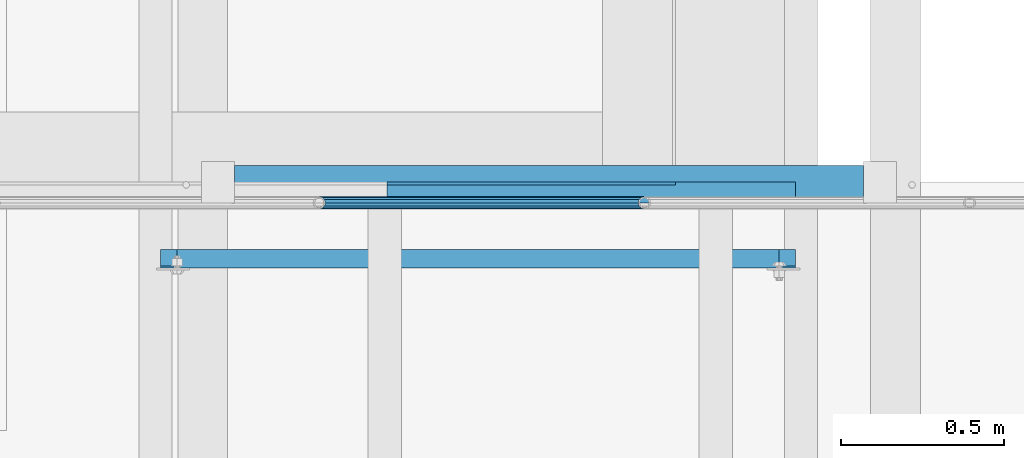
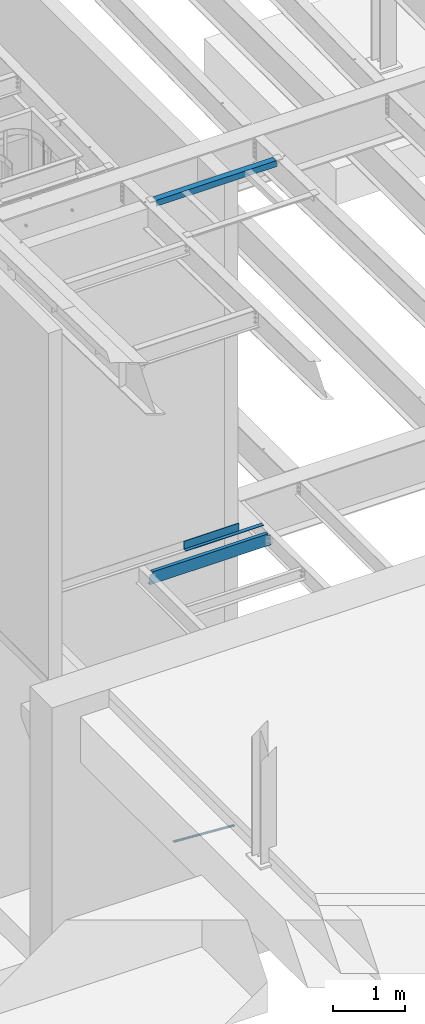
# One storey, part 1087 of 1763: 4 beams, 4 elements without a shape of their own.
"""IFC2X3 building model written with IfcOpenShell, lengths in millimetres."""

from ifc_helpers import new_model, si_unit, frame, origin_with_axes, place, context, subcontext, project, spatial, faceted_brep, material, type_object, element, aggregate, save


model = new_model("IFC2X3")

# Units and contexts
model_context = context("Model", 3, precision=1e-05, world=origin_with_axes())
body_context = subcontext(model_context, "Body", "Model", "MODEL_VIEW")
ifc_project = project(units=[si_unit("LENGTHUNIT", "METRE", prefix="MILLI"), si_unit("AREAUNIT", "SQUARE_METRE"), si_unit("VOLUMEUNIT", "CUBIC_METRE"), si_unit("MASSUNIT", "GRAM", prefix="KILO"), si_unit("TIMEUNIT", "SECOND"), si_unit("PLANEANGLEUNIT", "RADIAN"), si_unit("SOLIDANGLEUNIT", "STERADIAN"), si_unit("THERMODYNAMICTEMPERATUREUNIT", "DEGREE_CELSIUS"), si_unit("LUMINOUSINTENSITYUNIT", "LUMEN")], contexts=[model_context])

# Site, building, storey
site_placement = place(None, origin_with_axes())
site = spatial("IfcSite", under=ifc_project, at=site_placement, CompositionType="ELEMENT")
building_placement = place(site_placement, origin_with_axes())
building = spatial("IfcBuilding", under=site, at=building_placement, Name="Undefined", CompositionType="ELEMENT")
storey_placement = place(building_placement, origin_with_axes())
storey = spatial("IfcBuildingStorey", under=building, at=storey_placement, Name="Undefined", CompositionType="ELEMENT", Elevation=0.0)

# Assembly, beam
assembly_1_placement = place(storey_placement, origin_with_axes())
assembly_1 = element("IfcElementAssembly", 1, at=assembly_1_placement, inside=storey, Name="GUARDRAIL", AssemblyPlace="NOTDEFINED", PredefinedType="RIGID_FRAME")
ifc_material_1 = material()
beam_type_1 = type_object("IfcBeamType", PredefinedType="NOTDEFINED")
beam_1_placement = place(assembly_1_placement, frame((-83893.4544648736, 29197.2999999971, 277.811841144737), z_axis=(0.0, -1.0, 0.0), x_axis=(-0.997891522550524, 0.0, 0.0649038459707657)))
beam_1 = element("IfcBeam", 2, at=beam_1_placement, type_object=beam_type_1, material=ifc_material_1, Name="GUARDRAIL", context=body_context, shape_type="Brep", body=[
    faceted_brep([(1000.15019855548, 2.81943357549608e-11, -19.0499999999993), (989.985557506108, 9.5250000000251, -16.4977839420935), (991.224588240293, -9.52499999997053, -16.4977839420935), (982.257505670044, 13.3082123799786, 7.68349999999919), (980.060462398702, 15.3670000000229, 0.0), (979.820916456767, 19.050000000022, 0.0), (982.544523817283, 16.4977839421163, 9.52500000000146), (982.87174965936, 11.46671237998, 9.52500000000146), (982.87174965936, 11.46671237998, -9.52500000000146), (982.544523817283, 16.4977839421163, -9.52500000000146), (982.257505670044, 13.3082123799786, -7.68349999999919), (986.909019565966, 7.68350000002556, -13.3082123799541), (989.47189966141, 2.81943357549608e-11, -15.3669999999984), (987.908504358144, -7.68349999997099, -13.3082123799541), (984.363362158969, -11.4667123799254, -9.52500000000146), (984.690588001031, -16.4977839420635, -9.52500000000146), (983.988664111486, -13.3082123799259, -7.68349999999919), (982.059431983173, -15.3669999999702, 0.0), (982.298977925122, -19.0499999999693, 0.0), (983.988664111486, -13.3082123799259, 7.68349999999919), (984.363362158969, -11.4667123799254, 9.52500000000146), (984.690588001031, -16.4977839420635, 9.52500000000146), (1000.15019855546, 2.72848410531878e-11, 19.0499999999993), (991.224588240293, -9.52499999997053, 16.4977839420935), (989.985557506108, 9.5250000000251, 16.4977839420935), (987.908504358144, -7.68349999997099, 13.3082123799541), (989.47189966141, 2.72848410531878e-11, 15.3669999999984), (986.909019565966, 7.68350000002465, 13.3082123799541), (8.92561031517107, 9.52499999999873, -16.4977839420935), (15.4596105544624, 16.4977839420917, -9.52500000000146), (17.8512206303712, 19.0499999999975, 0.0), (18.0907665723062, 15.3669999999984, 0.0), (15.7868363965099, 11.4667123799545, -9.52500000000146), (16.1615344449092, 13.3082123799541, -7.68349999999919), (16.1615344449092, 13.3082123799541, 7.68349999999919), (15.7868363965099, 11.4667123799545, 9.52500000000146), (15.4596105544624, 16.4977839420917, 9.52500000000146), (8.92561031517107, 9.52499999999873, 16.4977839420935), (1.45519152283669e-11, 1.81898940354586e-12, 19.0499999999993), (10.1646410493704, -9.524999999996, 16.4977839420935), (10.1646410493704, -9.52499999999509, -16.4977839420935), (1.45519152283669e-11, 1.81898940354586e-12, -19.0499999999993), (17.6056747381954, -16.4977839420881, -9.52500000000146), (20.3292820987263, -19.0499999999938, 0.0), (17.6056747381954, -16.4977839420881, 9.52500000000146), (17.2784488961188, -11.4667123799518, -9.52500000000146), (13.2411789904436, -7.68349999999555, -13.3082123799541), (10.6782988949999, 1.81898940354586e-12, -15.3669999999984), (12.2416941982665, 7.68350000000009, -13.3082123799541), (20.0897361567768, -15.3669999999947, 0.0), (17.8926928863511, -13.3082123799504, -7.68349999999919), (17.2784488961188, -11.4667123799518, 9.52500000000146), (17.8926928863511, -13.3082123799504, 7.68349999999919), (12.2416941982665, 7.68350000000009, 13.3082123799541), (10.6782988949999, 1.81898940354586e-12, 15.3669999999984), (13.2411789904436, -7.68349999999646, 13.3082123799541)], [[[0, 1, 2]], [[3, 4, 5, 6, 7]], [[8, 9, 5, 4, 10]], [[2, 1, 9, 8, 11, 12, 13, 14, 15]], [[15, 14, 16, 17, 18]], [[18, 17, 19, 20, 21]], [[22, 23, 24]], [[21, 20, 25, 26, 27, 7, 6, 24, 23]], [[9, 1, 28, 29]], [[5, 9, 29, 30]], [[31, 30, 29, 32, 33]], [[34, 35, 36, 30, 31]], [[6, 5, 30, 36]], [[24, 6, 36, 37]], [[22, 24, 37, 38]], [[38, 37, 39]], [[0, 2, 40, 41]], [[2, 15, 42, 40]], [[15, 18, 43, 42]], [[18, 21, 44, 43]], [[21, 23, 39, 44]], [[23, 22, 38, 39]], [[1, 0, 41, 28]], [[40, 28, 41]], [[42, 45, 46, 47, 48, 32, 29, 28, 40]], [[43, 49, 50, 45, 42]], [[44, 51, 52, 49, 43]], [[39, 37, 36, 35, 53, 54, 55, 51, 44]], [[26, 25, 55, 54]], [[55, 25, 20, 19, 52, 51]], [[19, 17, 49, 52]], [[17, 16, 50, 49]], [[16, 14, 13, 46, 45, 50]], [[13, 12, 47, 46]], [[12, 11, 48, 47]], [[48, 11, 8, 10, 33, 32]], [[10, 4, 31, 33]], [[4, 3, 34, 31]], [[3, 7, 27, 53, 35, 34]], [[27, 26, 54, 53]]]),
])
aggregate(assembly_1, [beam_1])

assembly_2_placement = place(storey_placement, origin_with_axes())
assembly_2 = element("IfcElementAssembly", 3, at=assembly_2_placement, inside=storey, Name="ANGLE", AssemblyPlace="NOTDEFINED", PredefinedType="RIGID_FRAME")
ifc_material_2 = material(Name="STEEL/A36")
beam_type_2 = type_object("IfcBeamType", Name="L4X4X3/8", PredefinedType="NOTDEFINED")
beam_2_placement = place(assembly_2_placement, frame((-85249.0944165555, 29259.7228841285, 11255.437584779), z_axis=(0.0, -0.0209829029927569, -0.999779834654609), x_axis=(1.0, 0.0, 0.0)))
beam_2 = element("IfcBeam", 4, at=beam_2_placement, type_object=beam_type_2, material=ifc_material_2, Name="ANGLE", ObjectType="L4X4X3/8", context=body_context, shape_type="Brep", body=[
    faceted_brep([(98.4250000000029, 50.7999999999229, -50.8000000000175), (98.4250000000029, 50.8000000000102, 50.8000000001048), (2027.926333111, 50.8000000000102, 50.8000000001048), (2027.926333111, 50.7999999999229, -50.8000000000175), (98.4250000000029, 41.275000000016, 50.8000000000975), (2027.926333111, 41.275000000016, 50.8000000000975), (98.4250000000029, 41.2749999999378, -41.275000000016), (2027.926333111, 41.2749999999378, -41.275000000016), (98.4250000000029, -50.7999999999993, -41.2750000000997), (2027.926333111, -50.7999999999993, -41.2750000000997), (98.4250000000029, -50.800000000012, -50.8000000001084), (2027.926333111, -50.800000000012, -50.8000000001084)], [[[0, 1, 2, 3]], [[1, 4, 5, 2]], [[4, 6, 7, 5]], [[6, 8, 9, 7]], [[8, 10, 11, 9]], [[10, 0, 3, 11]], [[5, 7, 9, 11, 3, 2]], [[10, 8, 6, 4, 1, 0]]]),
])
aggregate(assembly_2, [beam_2])

assembly_3_placement = place(storey_placement, origin_with_axes())
assembly_3 = element("IfcElementAssembly", 5, at=assembly_3_placement, inside=storey, Name="BENT_PLATE", AssemblyPlace="NOTDEFINED", PredefinedType="RIGID_FRAME")
beam_type_3 = type_object("IfcBeamType", PredefinedType="NOTDEFINED")
beam_3_placement = place(assembly_3_placement, frame((-84056.0935496291, 29197.2999999971, 5199.0625), z_axis=(-1.0, 0.0, 0.0), x_axis=(0.0, 1.0, 0.0)))
beam_3 = element("IfcBeam", 6, at=beam_3_placement, type_object=beam_type_3, material=ifc_material_2, Name="BENT_PLATE", context=body_context, shape_type="Brep", body=[
    faceted_brep([(63.5, -4.7624969482431, -258.881263723684), (53.9749999999985, -4.76249999999982, -258.881263723684), (53.9749999999985, -4.76249999999982, -627.0625), (63.5, -4.7624969482431, -627.0625), (63.5, -134.937500000001, -258.881263723684), (53.9749999999985, -134.937496948242, -258.881263723684), (0.0, 4.76249999999982, -627.0625), (0.0, 4.76249999999982, 627.0625), (63.5, 4.76249999999982, 627.0625), (63.5, 4.76249999999982, -627.0625), (0.0, -4.76249999999982, -627.0625), (0.0, -4.76249999999982, -258.881263723684), (0.0, -4.76249999999982, 627.0625), (53.9749999999985, -4.76249999999982, 627.0625), (53.9749999999985, -134.937496948242, 627.0625), (63.5, -134.937496948242, 627.0625)], [[[0, 1, 2, 3]], [[4, 5, 1, 0]], [[6, 7, 8, 9]], [[10, 11, 12, 7, 6]], [[8, 7, 12, 13, 14, 15]], [[3, 9, 8, 15, 4, 0]], [[10, 6, 9, 3, 2]], [[12, 11, 10, 2, 1, 13]], [[14, 13, 1, 5]], [[15, 14, 5, 4]]]),
])
aggregate(assembly_3, [beam_3])

assembly_4_placement = place(storey_placement, origin_with_axes())
assembly_4 = element("IfcElementAssembly", 7, at=assembly_4_placement, inside=storey, Name="BEAM", AssemblyPlace="NOTDEFINED", PredefinedType="RIGID_FRAME")
beam_type_4 = type_object("IfcBeamType", Name="C8X11.5", PredefinedType="NOTDEFINED")
beam_4_placement = place(assembly_4_placement, frame((-83413.0372736984, 29025.85, 5092.7), z_axis=(0.0, 0.0, 1.0), x_axis=(-1.0, 0.0, 0.0)))
beam_4 = element("IfcBeam", 8, at=beam_4_placement, type_object=beam_type_4, material=ifc_material_2, Name="BEAM", ObjectType="C8X11.5", context=body_context, shape_type="Brep", body=[
    faceted_brep([(53.9750001907232, 22.2249999999985, 69.8499999999995), (53.9750001907232, 28.5750000000007, 69.8499999999995), (15.8749999999854, 28.5750000000007, 69.8499999999995), (15.8749999999854, 22.2249999999985, 69.8499999999995), (58.8350797087624, 22.2249999999985, 70.816729922587), (58.8350797087624, 28.5750000000007, 70.816729922587), (62.9552561769233, 22.2249999999985, 73.5697438230654), (62.9552561769233, 28.5750000000007, 73.5697438230654), (65.7082700774044, 22.2249999999985, 77.6899202912191), (65.7082700774044, 28.5750000000007, 77.6899202912191), (66.6749999999884, 22.2249999999985, 82.5499998092646), (66.6749999999884, 28.5750000000007, 82.5499998092646), (66.6749999999884, -28.5750000000007, 101.6), (66.6749999999884, 28.5750000000007, 101.6), (66.6749999999884, 22.2249999999985, 88.3723149999996), (66.6749999999884, -28.5750000000007, 96.8355949999996), (15.8749999999854, 22.2249999999985, -88.3723149999996), (15.8749999999854, -28.5750000000007, -96.8355949999996), (1965.24533793071, -28.5750000000007, -96.8355949999996), (1965.24533793071, 22.2249999999985, -88.3723149999996), (15.8749999999854, -28.5750000000007, -101.6), (1965.24533793071, -28.5750000000007, -101.6), (15.8749999999854, 28.5750000000007, -101.6), (1965.24533793071, 28.5750000000007, -101.6), (1965.24533793071, 28.5750000000007, 69.8499999999995), (1965.24533793071, 22.2249999999985, 69.8499999999995), (1927.14533773997, 28.5750000000007, 69.8499999999995), (1927.14533773997, 22.2249999999985, 69.8499999999995), (1922.28525822193, 28.5750000000007, 70.816729922587), (1922.28525822193, 22.2249999999985, 70.816729922587), (1918.16508175377, 28.5750000000007, 73.5697438230654), (1918.16508175377, 22.2249999999985, 73.5697438230654), (1915.41206785329, 28.5750000000007, 77.6899202912191), (1915.41206785329, 22.2249999999985, 77.6899202912191), (1914.44533793071, 28.5750000000007, 82.5499998092646), (1914.44533793071, 22.2249999999985, 82.5499998092646), (1914.44533793071, -28.5750000000007, 101.6), (1914.44533793071, -28.5750000000007, 96.8355949999996), (1914.44533793071, 22.2249999999985, 88.3723149999996), (1914.44533793071, 28.5750000000007, 101.6)], [[[0, 1, 2, 3]], [[4, 5, 1, 0]], [[6, 7, 5, 4]], [[8, 9, 7, 6]], [[10, 11, 9, 8]], [[12, 13, 11, 10, 14, 15]], [[16, 17, 18, 19]], [[17, 20, 21, 18]], [[20, 22, 23, 21]], [[19, 18, 21, 23, 24, 25]], [[25, 24, 26, 27]], [[27, 26, 28, 29]], [[29, 28, 30, 31]], [[31, 30, 32, 33]], [[33, 32, 34, 35]], [[36, 37, 38, 35, 34, 39]], [[37, 36, 12, 15]], [[38, 37, 15, 14]], [[8, 6, 4, 0, 3, 16, 19, 25, 27, 29, 31, 33, 35, 38, 14, 10]], [[22, 20, 17, 16, 3, 2]], [[39, 34, 32, 30, 28, 26, 24, 23, 22, 2, 1, 5, 7, 9, 11, 13]], [[36, 39, 13, 12]]]),
])
aggregate(assembly_4, [beam_4])

save(model, "model.ifc")
